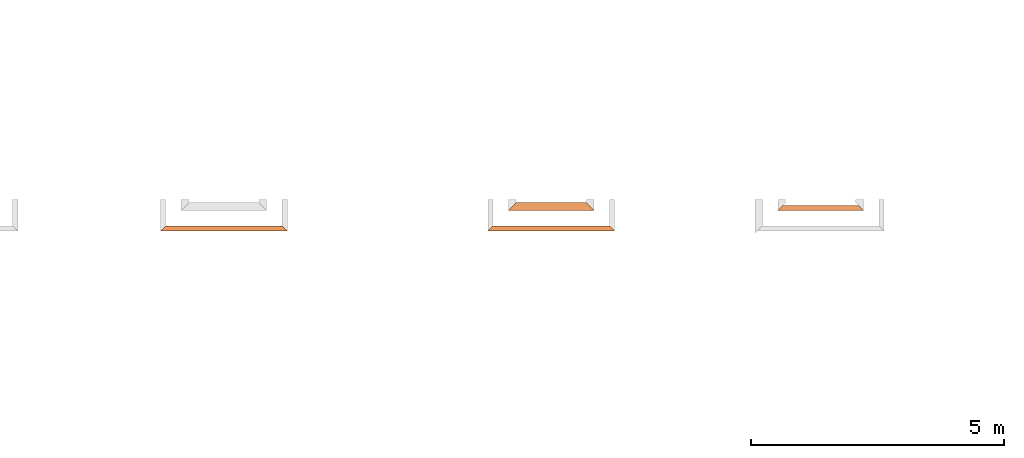
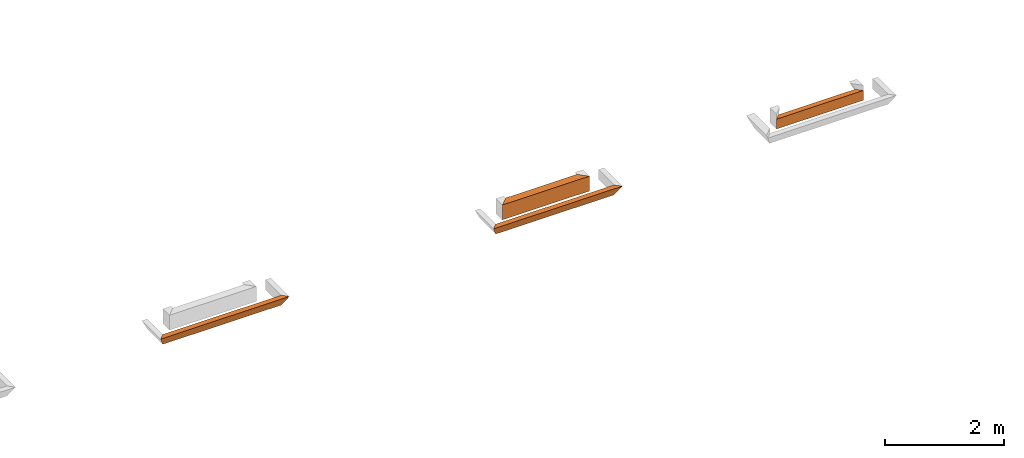
# One storey, part 3 of 8: 4 proxies.
"""IFC4 building model written with IfcOpenShell, lengths in feet."""

from ifc_helpers import new_model, entity, si_unit, converted_unit, derived_unit, direction, frame, origin, place, context, subcontext, project, spatial, type_object, element, save


model = new_model("IFC4")

# Units and contexts
model_context = context("Model", 3, precision=0.0001, world=origin(), true_north=direction((6.12303176911189e-17, 1.0)))
body_context = subcontext(model_context, "Body", "Model", "MODEL_VIEW")
ifc_project = project(units=[converted_unit("LENGTHUNIT", "FOOT", entity("IfcRatioMeasure", 0.3048), si_unit("LENGTHUNIT", "METRE"), dimensions=[1, 0, 0, 0, 0, 0, 0]), converted_unit("AREAUNIT", "SQUARE FOOT", entity("IfcRatioMeasure", 0.09290304), si_unit("AREAUNIT", "SQUARE_METRE"), dimensions=[2, 0, 0, 0, 0, 0, 0]), converted_unit("VOLUMEUNIT", "CUBIC FOOT", entity("IfcRatioMeasure", 0.028316846592), si_unit("VOLUMEUNIT", "CUBIC_METRE"), dimensions=[3, 0, 0, 0, 0, 0, 0]), converted_unit("PLANEANGLEUNIT", "DEGREE", entity("IfcRatioMeasure", 0.0174532925199433), si_unit("PLANEANGLEUNIT", "RADIAN"), dimensions=[0, 0, 0, 0, 0, 0, 0]), si_unit("MASSUNIT", "GRAM", prefix="KILO"), derived_unit("MASSDENSITYUNIT", [(si_unit("MASSUNIT", "GRAM", prefix="KILO"), 1), (si_unit("LENGTHUNIT", "METRE"), -3)]), derived_unit("MOMENTOFINERTIAUNIT", [(si_unit("LENGTHUNIT", "METRE"), 4)]), si_unit("TIMEUNIT", "SECOND"), si_unit("FREQUENCYUNIT", "HERTZ"), si_unit("THERMODYNAMICTEMPERATUREUNIT", "DEGREE_CELSIUS"), derived_unit("THERMALTRANSMITTANCEUNIT", [(si_unit("MASSUNIT", "GRAM", prefix="KILO"), 1), (si_unit("THERMODYNAMICTEMPERATUREUNIT", "KELVIN"), -1), (si_unit("TIMEUNIT", "SECOND"), -3)]), derived_unit("VOLUMETRICFLOWRATEUNIT", [(si_unit("LENGTHUNIT", "METRE"), 3), (si_unit("TIMEUNIT", "SECOND"), -1)]), si_unit("ELECTRICCURRENTUNIT", "AMPERE"), si_unit("ELECTRICVOLTAGEUNIT", "VOLT"), si_unit("POWERUNIT", "WATT"), si_unit("FORCEUNIT", "NEWTON"), si_unit("ILLUMINANCEUNIT", "LUX"), si_unit("LUMINOUSFLUXUNIT", "LUMEN"), si_unit("LUMINOUSINTENSITYUNIT", "CANDELA"), derived_unit("USERDEFINED", [(si_unit("MASSUNIT", "GRAM", prefix="KILO"), -1), (si_unit("LENGTHUNIT", "METRE"), -2), (si_unit("TIMEUNIT", "SECOND"), 3), (si_unit("LUMINOUSFLUXUNIT", "LUMEN"), 1)]), derived_unit("LINEARVELOCITYUNIT", [(si_unit("LENGTHUNIT", "METRE"), 1), (si_unit("TIMEUNIT", "SECOND"), -1)]), si_unit("PRESSUREUNIT", "PASCAL"), derived_unit("USERDEFINED", [(si_unit("LENGTHUNIT", "METRE"), -2), (si_unit("MASSUNIT", "GRAM", prefix="KILO"), 1), (si_unit("TIMEUNIT", "SECOND"), -2)]), derived_unit("LINEARFORCEUNIT", [(si_unit("MASSUNIT", "GRAM", prefix="KILO"), 1), (si_unit("LENGTHUNIT", "METRE"), 1), (si_unit("TIMEUNIT", "SECOND"), -2), (si_unit("LENGTHUNIT", "METRE"), -1)]), derived_unit("PLANARFORCEUNIT", [(si_unit("MASSUNIT", "GRAM", prefix="KILO"), 1), (si_unit("LENGTHUNIT", "METRE"), 1), (si_unit("TIMEUNIT", "SECOND"), -2), (si_unit("LENGTHUNIT", "METRE"), -2)])], contexts=[model_context])

# Site, building, storey
site_placement = place(None, origin())
site = spatial("IfcSite", under=ifc_project, at=site_placement, CompositionType="ELEMENT")
building_placement = place(site_placement, origin())
building = spatial("IfcBuilding", under=site, at=building_placement, CompositionType="ELEMENT")
storey_placement = place(building_placement, frame((0.0, 0.0, -12.6666666666667)))
storey = spatial("IfcBuildingStorey", under=building, at=storey_placement, Name="BASEMENT", CompositionType="ELEMENT", Elevation=-12.6666666666667)

# Proxies
building_element_proxy_type_1 = type_object("IfcBuildingElementProxyType", PredefinedType="NOTDEFINED")
proxy_1_placement = place(storey_placement, frame((-217.781129556124, 955.897091132649, 11.5833333333333)))
cartesian_point_1 = entity("IfcCartesianPoint", [7.87630257138792, 0.334635416666629, 0.0])
vertex_point_1 = entity("IfcVertexPoint", cartesian_point_1)
cartesian_point_2 = entity("IfcCartesianPoint", [7.87630257138792, 0.334635416666629, 0.669270833333334])
vertex_point_2 = entity("IfcVertexPoint", cartesian_point_2)
ifc_direction_1 = entity("IfcDirection", [0.0, 0.0, 1.0])
edge_curve_1 = entity("IfcEdgeCurve", vertex_point_1, vertex_point_2, entity("IfcTrimmedCurve", entity("IfcLine", cartesian_point_1, entity("IfcVector", ifc_direction_1, 1.0)), [cartesian_point_1], [cartesian_point_2], True, "CARTESIAN"), True)
cartesian_point_3 = entity("IfcCartesianPoint", [8.21093798805447, 0.0, 0.669270833333334])
vertex_point_3 = entity("IfcVertexPoint", cartesian_point_3)
edge_curve_2 = entity("IfcEdgeCurve", vertex_point_2, vertex_point_3, entity("IfcTrimmedCurve", entity("IfcLine", cartesian_point_2, entity("IfcVector", entity("IfcDirection", [0.707106781186548, -0.707106781186548, 0.0]), 1.0)), [cartesian_point_2], [cartesian_point_3], True, "CARTESIAN"), True)
edge_curve_3 = entity("IfcEdgeCurve", vertex_point_3, vertex_point_1, entity("IfcTrimmedCurve", entity("IfcLine", cartesian_point_3, entity("IfcVector", entity("IfcDirection", [-0.408248290463863, 0.408248290463829, -0.816496580927743]), 1.0)), [cartesian_point_3], [cartesian_point_1], True, "CARTESIAN"), True)
cartesian_point_4 = entity("IfcCartesianPoint", [0.334635416666714, 0.33463541666697, 0.0])
vertex_point_4 = entity("IfcVertexPoint", cartesian_point_4)
cartesian_point_5 = entity("IfcCartesianPoint", [0.0, 0.0, 0.669270833333334])
vertex_point_5 = entity("IfcVertexPoint", cartesian_point_5)
edge_curve_4 = entity("IfcEdgeCurve", vertex_point_4, vertex_point_5, entity("IfcTrimmedCurve", entity("IfcLine", cartesian_point_4, entity("IfcVector", entity("IfcDirection", [-0.408248290463863, -0.408248290463829, 0.816496580927743]), 1.0)), [cartesian_point_4], [cartesian_point_5], True, "CARTESIAN"), True)
cartesian_point_6 = entity("IfcCartesianPoint", [0.334635416666714, 0.33463541666697, 0.669270833333334])
vertex_point_6 = entity("IfcVertexPoint", cartesian_point_6)
edge_curve_5 = entity("IfcEdgeCurve", vertex_point_5, vertex_point_6, entity("IfcTrimmedCurve", entity("IfcLine", cartesian_point_5, entity("IfcVector", entity("IfcDirection", [0.707106781186517, 0.707106781186578, 0.0]), 1.0)), [cartesian_point_5], [cartesian_point_6], True, "CARTESIAN"), True)
edge_curve_6 = entity("IfcEdgeCurve", vertex_point_6, vertex_point_4, entity("IfcTrimmedCurve", entity("IfcLine", cartesian_point_6, entity("IfcVector", entity("IfcDirection", [0.0, 0.0, -1.0]), 1.0)), [cartesian_point_6], [cartesian_point_4], True, "CARTESIAN"), True)
ifc_direction_2 = entity("IfcDirection", [-1.0, 0.0, 0.0])
edge_curve_7 = entity("IfcEdgeCurve", vertex_point_1, vertex_point_4, entity("IfcTrimmedCurve", entity("IfcLine", cartesian_point_1, entity("IfcVector", ifc_direction_2, 1.0)), [cartesian_point_1], [cartesian_point_4], True, "CARTESIAN"), True)
cartesian_point_7 = entity("IfcCartesianPoint", [1.3346354166666, 0.33463541666697, 0.669270833333334])
vertex_point_7 = entity("IfcVertexPoint", cartesian_point_7)
ifc_direction_3 = entity("IfcDirection", [1.0, 0.0, 0.0])
edge_curve_8 = entity("IfcEdgeCurve", vertex_point_6, vertex_point_7, entity("IfcTrimmedCurve", entity("IfcLine", cartesian_point_6, entity("IfcVector", ifc_direction_3, 1.0)), [cartesian_point_6], [cartesian_point_7], True, "CARTESIAN"), True)
cartesian_point_8 = entity("IfcCartesianPoint", [4.45963573776979, 0.334635416666742, 0.669270833333334])
vertex_point_8 = entity("IfcVertexPoint", cartesian_point_8)
edge_curve_9 = entity("IfcEdgeCurve", vertex_point_7, vertex_point_8, entity("IfcTrimmedCurve", entity("IfcLine", cartesian_point_7, entity("IfcVector", ifc_direction_3, 1.0)), [cartesian_point_7], [cartesian_point_8], True, "CARTESIAN"), True)
cartesian_point_9 = entity("IfcCartesianPoint", [5.62630240443644, 0.334635416666742, 0.669270833333334])
vertex_point_9 = entity("IfcVertexPoint", cartesian_point_9)
edge_curve_10 = entity("IfcEdgeCurve", vertex_point_8, vertex_point_9, entity("IfcTrimmedCurve", entity("IfcLine", cartesian_point_8, entity("IfcVector", ifc_direction_3, 1.0)), [cartesian_point_8], [cartesian_point_9], True, "CARTESIAN"), True)
cartesian_point_10 = entity("IfcCartesianPoint", [6.87630257138792, 0.334635416666629, 0.669270833333334])
vertex_point_10 = entity("IfcVertexPoint", cartesian_point_10)
edge_curve_11 = entity("IfcEdgeCurve", vertex_point_9, vertex_point_10, entity("IfcTrimmedCurve", entity("IfcLine", cartesian_point_9, entity("IfcVector", ifc_direction_3, 1.0)), [cartesian_point_9], [cartesian_point_10], True, "CARTESIAN"), True)
edge_curve_12 = entity("IfcEdgeCurve", vertex_point_10, vertex_point_2, entity("IfcTrimmedCurve", entity("IfcLine", cartesian_point_10, entity("IfcVector", ifc_direction_3, 1.0)), [cartesian_point_10], [cartesian_point_2], True, "CARTESIAN"), True)
edge_curve_13 = entity("IfcEdgeCurve", vertex_point_3, vertex_point_5, entity("IfcTrimmedCurve", entity("IfcLine", cartesian_point_3, entity("IfcVector", ifc_direction_2, 1.0)), [cartesian_point_3], [cartesian_point_5], True, "CARTESIAN"), True)
element("IfcBuildingElementProxy", 1, at=proxy_1_placement, inside=storey, type_object=building_element_proxy_type_1, PredefinedType="NOTDEFINED", context=body_context, shape_type="AdvancedBrep", body=[
    entity("IfcAdvancedBrep", entity("IfcClosedShell", [entity("IfcAdvancedFace", [entity("IfcFaceOuterBound", entity("IfcEdgeLoop", [entity("IfcOrientedEdge", None, None, edge_curve_1, True), entity("IfcOrientedEdge", None, None, edge_curve_2, True), entity("IfcOrientedEdge", None, None, edge_curve_3, True)]), True)], entity("IfcPlane", entity("IfcAxis2Placement3D", entity("IfcCartesianPoint", [7.87630257138792, 0.334635416666629, 2.0]), entity("IfcDirection", [0.707106781186562, 0.707106781186533, 0.0]), entity("IfcDirection", [-0.707106781186533, 0.707106781186562, 0.0]))), True), entity("IfcAdvancedFace", [entity("IfcFaceOuterBound", entity("IfcEdgeLoop", [entity("IfcOrientedEdge", None, None, edge_curve_4, True), entity("IfcOrientedEdge", None, None, edge_curve_5, True), entity("IfcOrientedEdge", None, None, edge_curve_6, True)]), True)], entity("IfcPlane", entity("IfcAxis2Placement3D", entity("IfcCartesianPoint", [0.3346354166666, 0.334635416666856, 2.0]), entity("IfcDirection", [-0.707106781186548, 0.707106781186548, 0.0]), entity("IfcDirection", [0.707106781186548, 0.707106781186548, 0.0]))), True), entity("IfcAdvancedFace", [entity("IfcFaceOuterBound", entity("IfcEdgeLoop", [entity("IfcOrientedEdge", None, None, edge_curve_7, True), entity("IfcOrientedEdge", None, None, edge_curve_6, False), entity("IfcOrientedEdge", None, None, edge_curve_8, True), entity("IfcOrientedEdge", None, None, edge_curve_9, True), entity("IfcOrientedEdge", None, None, edge_curve_10, True), entity("IfcOrientedEdge", None, None, edge_curve_11, True), entity("IfcOrientedEdge", None, None, edge_curve_12, True), entity("IfcOrientedEdge", None, None, edge_curve_1, False)]), True)], entity("IfcPlane", entity("IfcAxis2Placement3D", cartesian_point_1, entity("IfcDirection", [0.0, 1.0, 0.0]), ifc_direction_2)), True), entity("IfcAdvancedFace", [entity("IfcFaceOuterBound", entity("IfcEdgeLoop", [entity("IfcOrientedEdge", None, None, edge_curve_7, False), entity("IfcOrientedEdge", None, None, edge_curve_3, False), entity("IfcOrientedEdge", None, None, edge_curve_13, True), entity("IfcOrientedEdge", None, None, edge_curve_4, False)]), True)], entity("IfcPlane", entity("IfcAxis2Placement3D", entity("IfcCartesianPoint", [8.37630257138792, -0.165364583333371, 1.0]), entity("IfcDirection", [0.0, -0.894427190999915, -0.447213595499961]), ifc_direction_2)), True), entity("IfcAdvancedFace", [entity("IfcFaceOuterBound", entity("IfcEdgeLoop", [entity("IfcOrientedEdge", None, None, edge_curve_2, False), entity("IfcOrientedEdge", None, None, edge_curve_12, False), entity("IfcOrientedEdge", None, None, edge_curve_11, False), entity("IfcOrientedEdge", None, None, edge_curve_10, False), entity("IfcOrientedEdge", None, None, edge_curve_9, False), entity("IfcOrientedEdge", None, None, edge_curve_8, False), entity("IfcOrientedEdge", None, None, edge_curve_5, False), entity("IfcOrientedEdge", None, None, edge_curve_13, False)]), True)], entity("IfcPlane", entity("IfcAxis2Placement3D", entity("IfcCartesianPoint", [76.0429767451503, 2.96484375000114, 0.669270833333334]), ifc_direction_1, ifc_direction_3)), True)])),
])
building_element_proxy_type_2 = type_object("IfcBuildingElementProxyType", PredefinedType="NOTDEFINED")
proxy_2_placement = place(storey_placement, frame((-195.238160652997, 957.231726549315, 11.5833333333333)))
cartesian_point_11 = entity("IfcCartesianPoint", [5.54166715473104, 0.0, 0.0])
vertex_point_11 = entity("IfcVertexPoint", cartesian_point_11)
cartesian_point_12 = entity("IfcCartesianPoint", [5.04166715473104, 0.5, 1.0])
vertex_point_12 = entity("IfcVertexPoint", cartesian_point_12)
edge_curve_14 = entity("IfcEdgeCurve", vertex_point_11, vertex_point_12, entity("IfcTrimmedCurve", entity("IfcLine", cartesian_point_11, entity("IfcVector", entity("IfcDirection", [-0.408248290463864, 0.408248290463864, 0.816496580927725]), 1.0)), [cartesian_point_11], [cartesian_point_12], True, "CARTESIAN"), True)
cartesian_point_13 = entity("IfcCartesianPoint", [5.54166715473104, 0.0, 1.0])
vertex_point_13 = entity("IfcVertexPoint", cartesian_point_13)
edge_curve_15 = entity("IfcEdgeCurve", vertex_point_12, vertex_point_13, entity("IfcTrimmedCurve", entity("IfcLine", cartesian_point_12, entity("IfcVector", entity("IfcDirection", [0.707106781186547, -0.707106781186547, 0.0]), 1.0)), [cartesian_point_12], [cartesian_point_13], True, "CARTESIAN"), True)
cartesian_point_14 = entity("IfcCartesianPoint", [5.54166715473104, 0.0, 0.669270833333334])
vertex_point_14 = entity("IfcVertexPoint", cartesian_point_14)
ifc_direction_4 = entity("IfcDirection", [0.0, 0.0, -1.0])
edge_curve_16 = entity("IfcEdgeCurve", vertex_point_13, vertex_point_14, entity("IfcTrimmedCurve", entity("IfcLine", cartesian_point_13, entity("IfcVector", ifc_direction_4, 1.0)), [cartesian_point_13], [cartesian_point_14], True, "CARTESIAN"), True)
edge_curve_17 = entity("IfcEdgeCurve", vertex_point_14, vertex_point_11, entity("IfcTrimmedCurve", entity("IfcLine", cartesian_point_14, entity("IfcVector", ifc_direction_4, 1.0)), [cartesian_point_14], [cartesian_point_11], True, "CARTESIAN"), True)
cartesian_point_15 = entity("IfcCartesianPoint", [0.499999999999972, 0.500000000000227, 1.0])
vertex_point_15 = entity("IfcVertexPoint", cartesian_point_15)
cartesian_point_16 = entity("IfcCartesianPoint", [0.0, 0.0, 0.0])
vertex_point_16 = entity("IfcVertexPoint", cartesian_point_16)
edge_curve_18 = entity("IfcEdgeCurve", vertex_point_15, vertex_point_16, entity("IfcTrimmedCurve", entity("IfcLine", cartesian_point_15, entity("IfcVector", entity("IfcDirection", [-0.408248290463845, -0.408248290463868, -0.816496580927732]), 1.0)), [cartesian_point_15], [cartesian_point_16], True, "CARTESIAN"), True)
cartesian_point_17 = entity("IfcCartesianPoint", [0.0, 0.0, 0.669270833333334])
vertex_point_17 = entity("IfcVertexPoint", cartesian_point_17)
ifc_direction_5 = entity("IfcDirection", [0.0, 0.0, 1.0])
edge_curve_19 = entity("IfcEdgeCurve", vertex_point_16, vertex_point_17, entity("IfcTrimmedCurve", entity("IfcLine", cartesian_point_16, entity("IfcVector", ifc_direction_5, 1.0)), [cartesian_point_16], [cartesian_point_17], True, "CARTESIAN"), True)
cartesian_point_18 = entity("IfcCartesianPoint", [0.0, 0.0, 1.0])
vertex_point_18 = entity("IfcVertexPoint", cartesian_point_18)
edge_curve_20 = entity("IfcEdgeCurve", vertex_point_17, vertex_point_18, entity("IfcTrimmedCurve", entity("IfcLine", cartesian_point_17, entity("IfcVector", ifc_direction_5, 1.0)), [cartesian_point_17], [cartesian_point_18], True, "CARTESIAN"), True)
edge_curve_21 = entity("IfcEdgeCurve", vertex_point_18, vertex_point_15, entity("IfcTrimmedCurve", entity("IfcLine", cartesian_point_18, entity("IfcVector", entity("IfcDirection", [0.707106781186527, 0.707106781186568, 0.0]), 1.0)), [cartesian_point_18], [cartesian_point_15], True, "CARTESIAN"), True)
ifc_direction_6 = entity("IfcDirection", [-1.0, 0.0, 0.0])
edge_curve_22 = entity("IfcEdgeCurve", vertex_point_11, vertex_point_16, entity("IfcTrimmedCurve", entity("IfcLine", cartesian_point_11, entity("IfcVector", ifc_direction_6, 1.0)), [cartesian_point_11], [cartesian_point_16], True, "CARTESIAN"), True)
ifc_direction_7 = entity("IfcDirection", [1.0, 0.0, 0.0])
edge_curve_23 = entity("IfcEdgeCurve", vertex_point_15, vertex_point_12, entity("IfcTrimmedCurve", entity("IfcLine", cartesian_point_12, entity("IfcVector", ifc_direction_7, 1.0)), [cartesian_point_15], [cartesian_point_12], True, "CARTESIAN"), True)
edge_curve_24 = entity("IfcEdgeCurve", vertex_point_18, vertex_point_13, entity("IfcTrimmedCurve", entity("IfcLine", cartesian_point_13, entity("IfcVector", ifc_direction_7, 1.0)), [cartesian_point_18], [cartesian_point_13], True, "CARTESIAN"), True)
element("IfcBuildingElementProxy", 2, at=proxy_2_placement, inside=storey, type_object=building_element_proxy_type_2, PredefinedType="NOTDEFINED", context=body_context, shape_type="AdvancedBrep", body=[
    entity("IfcAdvancedBrep", entity("IfcClosedShell", [entity("IfcAdvancedFace", [entity("IfcFaceOuterBound", entity("IfcEdgeLoop", [entity("IfcOrientedEdge", None, None, edge_curve_14, True), entity("IfcOrientedEdge", None, None, edge_curve_15, True), entity("IfcOrientedEdge", None, None, edge_curve_16, True), entity("IfcOrientedEdge", None, None, edge_curve_17, True)]), True)], entity("IfcPlane", entity("IfcAxis2Placement3D", entity("IfcCartesianPoint", [5.54166715473104, 0.0, 2.0]), entity("IfcDirection", [0.707106781186562, 0.707106781186533, 0.0]), entity("IfcDirection", [-0.707106781186533, 0.707106781186562, 0.0]))), True), entity("IfcAdvancedFace", [entity("IfcFaceOuterBound", entity("IfcEdgeLoop", [entity("IfcOrientedEdge", None, None, edge_curve_18, True), entity("IfcOrientedEdge", None, None, edge_curve_19, True), entity("IfcOrientedEdge", None, None, edge_curve_20, True), entity("IfcOrientedEdge", None, None, edge_curve_21, True)]), True)], entity("IfcPlane", entity("IfcAxis2Placement3D", entity("IfcCartesianPoint", [0.0, 0.0, 2.0]), entity("IfcDirection", [-0.707106781186548, 0.707106781186548, 0.0]), entity("IfcDirection", [0.707106781186548, 0.707106781186548, 0.0]))), True), entity("IfcAdvancedFace", [entity("IfcFaceOuterBound", entity("IfcEdgeLoop", [entity("IfcOrientedEdge", None, None, edge_curve_14, False), entity("IfcOrientedEdge", None, None, edge_curve_22, True), entity("IfcOrientedEdge", None, None, edge_curve_18, False), entity("IfcOrientedEdge", None, None, edge_curve_23, True)]), True)], entity("IfcPlane", entity("IfcAxis2Placement3D", cartesian_point_11, entity("IfcDirection", [0.0, 0.894427190999915, -0.447213595499961]), ifc_direction_6)), True), entity("IfcAdvancedFace", [entity("IfcFaceOuterBound", entity("IfcEdgeLoop", [entity("IfcOrientedEdge", None, None, edge_curve_15, False), entity("IfcOrientedEdge", None, None, edge_curve_23, False), entity("IfcOrientedEdge", None, None, edge_curve_21, False), entity("IfcOrientedEdge", None, None, edge_curve_24, True)]), True)], entity("IfcPlane", entity("IfcAxis2Placement3D", cartesian_point_12, ifc_direction_5, ifc_direction_6)), True), entity("IfcAdvancedFace", [entity("IfcFaceOuterBound", entity("IfcEdgeLoop", [entity("IfcOrientedEdge", None, None, edge_curve_24, False), entity("IfcOrientedEdge", None, None, edge_curve_20, False), entity("IfcOrientedEdge", None, None, edge_curve_19, False), entity("IfcOrientedEdge", None, None, edge_curve_22, False), entity("IfcOrientedEdge", None, None, edge_curve_17, False), entity("IfcOrientedEdge", None, None, edge_curve_16, False)]), True)], entity("IfcPlane", entity("IfcAxis2Placement3D", cartesian_point_13, entity("IfcDirection", [0.0, -1.0, 0.0]), ifc_direction_6)), True)])),
])
building_element_proxy_type_3 = type_object("IfcBuildingElementProxyType", PredefinedType="NOTDEFINED")
proxy_3_placement = place(storey_placement, frame((-196.572796069664, 955.897091132648, 11.5833333333333)))
cartesian_point_19 = entity("IfcCartesianPoint", [7.87630257139756, 0.334635416666629, 0.0])
vertex_point_19 = entity("IfcVertexPoint", cartesian_point_19)
cartesian_point_20 = entity("IfcCartesianPoint", [7.87630257139756, 0.334635416666629, 0.669270833333334])
vertex_point_20 = entity("IfcVertexPoint", cartesian_point_20)
ifc_direction_8 = entity("IfcDirection", [0.0, 0.0, 1.0])
edge_curve_25 = entity("IfcEdgeCurve", vertex_point_19, vertex_point_20, entity("IfcTrimmedCurve", entity("IfcLine", cartesian_point_19, entity("IfcVector", ifc_direction_8, 1.0)), [cartesian_point_19], [cartesian_point_20], True, "CARTESIAN"), True)
cartesian_point_21 = entity("IfcCartesianPoint", [8.21093798806413, 0.0, 0.669270833333334])
vertex_point_21 = entity("IfcVertexPoint", cartesian_point_21)
edge_curve_26 = entity("IfcEdgeCurve", vertex_point_20, vertex_point_21, entity("IfcTrimmedCurve", entity("IfcLine", cartesian_point_20, entity("IfcVector", entity("IfcDirection", [0.707106781186488, -0.707106781186608, 0.0]), 1.0)), [cartesian_point_20], [cartesian_point_21], True, "CARTESIAN"), True)
edge_curve_27 = entity("IfcEdgeCurve", vertex_point_21, vertex_point_19, entity("IfcTrimmedCurve", entity("IfcLine", cartesian_point_21, entity("IfcVector", entity("IfcDirection", [-0.408248290463863, 0.408248290463829, -0.816496580927743]), 1.0)), [cartesian_point_21], [cartesian_point_19], True, "CARTESIAN"), True)
cartesian_point_22 = entity("IfcCartesianPoint", [0.334635416666686, 0.33463541666697, 0.0])
vertex_point_22 = entity("IfcVertexPoint", cartesian_point_22)
cartesian_point_23 = entity("IfcCartesianPoint", [0.0, 0.0, 0.669270833333334])
vertex_point_23 = entity("IfcVertexPoint", cartesian_point_23)
edge_curve_28 = entity("IfcEdgeCurve", vertex_point_22, vertex_point_23, entity("IfcTrimmedCurve", entity("IfcLine", cartesian_point_22, entity("IfcVector", entity("IfcDirection", [-0.408248290463863, -0.408248290463829, 0.816496580927743]), 1.0)), [cartesian_point_22], [cartesian_point_23], True, "CARTESIAN"), True)
cartesian_point_24 = entity("IfcCartesianPoint", [0.334635416666686, 0.33463541666697, 0.669270833333334])
vertex_point_24 = entity("IfcVertexPoint", cartesian_point_24)
edge_curve_29 = entity("IfcEdgeCurve", vertex_point_23, vertex_point_24, entity("IfcTrimmedCurve", entity("IfcLine", cartesian_point_23, entity("IfcVector", entity("IfcDirection", [0.707106781186488, 0.707106781186608, 0.0]), 1.0)), [cartesian_point_23], [cartesian_point_24], True, "CARTESIAN"), True)
edge_curve_30 = entity("IfcEdgeCurve", vertex_point_24, vertex_point_22, entity("IfcTrimmedCurve", entity("IfcLine", cartesian_point_24, entity("IfcVector", entity("IfcDirection", [0.0, 0.0, -1.0]), 1.0)), [cartesian_point_24], [cartesian_point_22], True, "CARTESIAN"), True)
ifc_direction_9 = entity("IfcDirection", [-1.0, 0.0, 0.0])
edge_curve_31 = entity("IfcEdgeCurve", vertex_point_19, vertex_point_22, entity("IfcTrimmedCurve", entity("IfcLine", cartesian_point_19, entity("IfcVector", ifc_direction_9, 1.0)), [cartesian_point_19], [cartesian_point_22], True, "CARTESIAN"), True)
cartesian_point_25 = entity("IfcCartesianPoint", [1.33463541666657, 0.33463541666697, 0.669270833333334])
vertex_point_25 = entity("IfcVertexPoint", cartesian_point_25)
ifc_direction_10 = entity("IfcDirection", [1.0, 0.0, 0.0])
edge_curve_32 = entity("IfcEdgeCurve", vertex_point_24, vertex_point_25, entity("IfcTrimmedCurve", entity("IfcLine", cartesian_point_24, entity("IfcVector", ifc_direction_10, 1.0)), [cartesian_point_24], [cartesian_point_25], True, "CARTESIAN"), True)
cartesian_point_26 = entity("IfcCartesianPoint", [2.5846355840587, 0.334635416666856, 0.669270833333334])
vertex_point_26 = entity("IfcVertexPoint", cartesian_point_26)
edge_curve_33 = entity("IfcEdgeCurve", vertex_point_25, vertex_point_26, entity("IfcTrimmedCurve", entity("IfcLine", cartesian_point_25, entity("IfcVector", ifc_direction_10, 1.0)), [cartesian_point_25], [cartesian_point_26], True, "CARTESIAN"), True)
cartesian_point_27 = entity("IfcCartesianPoint", [3.75130225072536, 0.334635416666856, 0.669270833333334])
vertex_point_27 = entity("IfcVertexPoint", cartesian_point_27)
edge_curve_34 = entity("IfcEdgeCurve", vertex_point_26, vertex_point_27, entity("IfcTrimmedCurve", entity("IfcLine", cartesian_point_26, entity("IfcVector", ifc_direction_10, 1.0)), [cartesian_point_26], [cartesian_point_27], True, "CARTESIAN"), True)
cartesian_point_28 = entity("IfcCartesianPoint", [6.87630257139756, 0.334635416666629, 0.669270833333334])
vertex_point_28 = entity("IfcVertexPoint", cartesian_point_28)
edge_curve_35 = entity("IfcEdgeCurve", vertex_point_27, vertex_point_28, entity("IfcTrimmedCurve", entity("IfcLine", cartesian_point_27, entity("IfcVector", ifc_direction_10, 1.0)), [cartesian_point_27], [cartesian_point_28], True, "CARTESIAN"), True)
edge_curve_36 = entity("IfcEdgeCurve", vertex_point_28, vertex_point_20, entity("IfcTrimmedCurve", entity("IfcLine", cartesian_point_28, entity("IfcVector", ifc_direction_10, 1.0)), [cartesian_point_28], [cartesian_point_20], True, "CARTESIAN"), True)
edge_curve_37 = entity("IfcEdgeCurve", vertex_point_21, vertex_point_23, entity("IfcTrimmedCurve", entity("IfcLine", cartesian_point_21, entity("IfcVector", ifc_direction_9, 1.0)), [cartesian_point_21], [cartesian_point_23], True, "CARTESIAN"), True)
element("IfcBuildingElementProxy", 3, at=proxy_3_placement, inside=storey, type_object=building_element_proxy_type_3, PredefinedType="NOTDEFINED", context=body_context, shape_type="AdvancedBrep", body=[
    entity("IfcAdvancedBrep", entity("IfcClosedShell", [entity("IfcAdvancedFace", [entity("IfcFaceOuterBound", entity("IfcEdgeLoop", [entity("IfcOrientedEdge", None, None, edge_curve_25, True), entity("IfcOrientedEdge", None, None, edge_curve_26, True), entity("IfcOrientedEdge", None, None, edge_curve_27, True)]), True)], entity("IfcPlane", entity("IfcAxis2Placement3D", entity("IfcCartesianPoint", [7.87630257139756, 0.334635416666629, 2.0]), entity("IfcDirection", [0.707106781186562, 0.707106781186533, 0.0]), entity("IfcDirection", [-0.707106781186533, 0.707106781186562, 0.0]))), True), entity("IfcAdvancedFace", [entity("IfcFaceOuterBound", entity("IfcEdgeLoop", [entity("IfcOrientedEdge", None, None, edge_curve_28, True), entity("IfcOrientedEdge", None, None, edge_curve_29, True), entity("IfcOrientedEdge", None, None, edge_curve_30, True)]), True)], entity("IfcPlane", entity("IfcAxis2Placement3D", entity("IfcCartesianPoint", [0.334635416666572, 0.334635416666856, 2.0]), entity("IfcDirection", [-0.707106781186548, 0.707106781186548, 0.0]), entity("IfcDirection", [0.707106781186548, 0.707106781186548, 0.0]))), True), entity("IfcAdvancedFace", [entity("IfcFaceOuterBound", entity("IfcEdgeLoop", [entity("IfcOrientedEdge", None, None, edge_curve_31, True), entity("IfcOrientedEdge", None, None, edge_curve_30, False), entity("IfcOrientedEdge", None, None, edge_curve_32, True), entity("IfcOrientedEdge", None, None, edge_curve_33, True), entity("IfcOrientedEdge", None, None, edge_curve_34, True), entity("IfcOrientedEdge", None, None, edge_curve_35, True), entity("IfcOrientedEdge", None, None, edge_curve_36, True), entity("IfcOrientedEdge", None, None, edge_curve_25, False)]), True)], entity("IfcPlane", entity("IfcAxis2Placement3D", cartesian_point_19, entity("IfcDirection", [0.0, 1.0, 0.0]), ifc_direction_9)), True), entity("IfcAdvancedFace", [entity("IfcFaceOuterBound", entity("IfcEdgeLoop", [entity("IfcOrientedEdge", None, None, edge_curve_31, False), entity("IfcOrientedEdge", None, None, edge_curve_27, False), entity("IfcOrientedEdge", None, None, edge_curve_37, True), entity("IfcOrientedEdge", None, None, edge_curve_28, False)]), True)], entity("IfcPlane", entity("IfcAxis2Placement3D", entity("IfcCartesianPoint", [8.37630257139756, -0.165364583333371, 1.0]), entity("IfcDirection", [0.0, -0.894427190999915, -0.447213595499961]), ifc_direction_9)), True), entity("IfcAdvancedFace", [entity("IfcFaceOuterBound", entity("IfcEdgeLoop", [entity("IfcOrientedEdge", None, None, edge_curve_26, False), entity("IfcOrientedEdge", None, None, edge_curve_36, False), entity("IfcOrientedEdge", None, None, edge_curve_35, False), entity("IfcOrientedEdge", None, None, edge_curve_34, False), entity("IfcOrientedEdge", None, None, edge_curve_33, False), entity("IfcOrientedEdge", None, None, edge_curve_32, False), entity("IfcOrientedEdge", None, None, edge_curve_29, False), entity("IfcOrientedEdge", None, None, edge_curve_37, False)]), True)], entity("IfcPlane", entity("IfcAxis2Placement3D", entity("IfcCartesianPoint", [54.8346432586897, 2.96484375000216, 0.669270833333334]), ifc_direction_8, ifc_direction_10)), True)])),
])
building_element_proxy_type_4 = type_object("IfcBuildingElementProxyType", PredefinedType="NOTDEFINED")
proxy_4_placement = place(storey_placement, frame((-177.779827442686, 957.231726549315, 11.5833333333333)))
cartesian_point_29 = entity("IfcCartesianPoint", [5.5416671547116, 0.0, 0.0])
vertex_point_29 = entity("IfcVertexPoint", cartesian_point_29)
cartesian_point_30 = entity("IfcCartesianPoint", [5.21181498777273, 0.329852166938736, 0.659704333877778])
vertex_point_30 = entity("IfcVertexPoint", cartesian_point_30)
edge_curve_38 = entity("IfcEdgeCurve", vertex_point_29, vertex_point_30, entity("IfcTrimmedCurve", entity("IfcLine", cartesian_point_29, entity("IfcVector", entity("IfcDirection", [-0.408248290463861, 0.408248290463826, 0.816496580927745]), 1.0)), [cartesian_point_29], [cartesian_point_30], True, "CARTESIAN"), True)
cartesian_point_31 = entity("IfcCartesianPoint", [5.5416671547116, 0.0, 0.666576254022337])
vertex_point_31 = entity("IfcVertexPoint", cartesian_point_31)
edge_curve_39 = entity("IfcEdgeCurve", vertex_point_30, vertex_point_31, entity("IfcTrimmedCurve", entity("IfcLine", cartesian_point_30, entity("IfcVector", entity("IfcDirection", [0.707030067676022, -0.707030067676022, 0.0147297930765863]), 1.0)), [cartesian_point_30], [cartesian_point_31], True, "CARTESIAN"), True)
edge_curve_40 = entity("IfcEdgeCurve", vertex_point_31, vertex_point_29, entity("IfcTrimmedCurve", entity("IfcLine", cartesian_point_31, entity("IfcVector", entity("IfcDirection", [0.0, 0.0, -1.0]), 1.0)), [cartesian_point_31], [cartesian_point_29], True, "CARTESIAN"), True)
cartesian_point_32 = entity("IfcCartesianPoint", [0.0, 0.0, 0.0])
vertex_point_32 = entity("IfcVertexPoint", cartesian_point_32)
cartesian_point_33 = entity("IfcCartesianPoint", [0.0, 0.0, 0.666576254022335])
vertex_point_33 = entity("IfcVertexPoint", cartesian_point_33)
edge_curve_41 = entity("IfcEdgeCurve", vertex_point_32, vertex_point_33, entity("IfcTrimmedCurve", entity("IfcLine", cartesian_point_32, entity("IfcVector", entity("IfcDirection", [0.0, 0.0, 1.0]), 1.0)), [cartesian_point_32], [cartesian_point_33], True, "CARTESIAN"), True)
cartesian_point_34 = entity("IfcCartesianPoint", [0.329852166938849, 0.329852166938963, 0.659704333877773])
vertex_point_34 = entity("IfcVertexPoint", cartesian_point_34)
edge_curve_42 = entity("IfcEdgeCurve", vertex_point_33, vertex_point_34, entity("IfcTrimmedCurve", entity("IfcLine", cartesian_point_33, entity("IfcVector", entity("IfcDirection", [0.707030067676022, 0.707030067676022, -0.0147297930765841]), 1.0)), [cartesian_point_33], [cartesian_point_34], True, "CARTESIAN"), True)
edge_curve_43 = entity("IfcEdgeCurve", vertex_point_34, vertex_point_32, entity("IfcTrimmedCurve", entity("IfcLine", cartesian_point_34, entity("IfcVector", entity("IfcDirection", [-0.408248290463863, -0.408248290463828, -0.816496580927743]), 1.0)), [cartesian_point_34], [cartesian_point_32], True, "CARTESIAN"), True)
ifc_direction_11 = entity("IfcDirection", [-1.0, 0.0, 0.0])
edge_curve_44 = entity("IfcEdgeCurve", vertex_point_29, vertex_point_32, entity("IfcTrimmedCurve", entity("IfcLine", cartesian_point_29, entity("IfcVector", ifc_direction_11, 1.0)), [cartesian_point_29], [cartesian_point_32], True, "CARTESIAN"), True)
edge_curve_45 = entity("IfcEdgeCurve", vertex_point_34, vertex_point_30, entity("IfcTrimmedCurve", entity("IfcLine", cartesian_point_34, entity("IfcVector", entity("IfcDirection", [1.0, 0.0, 0.0]), 1.0)), [cartesian_point_34], [cartesian_point_30], True, "CARTESIAN"), True)
edge_curve_46 = entity("IfcEdgeCurve", vertex_point_31, vertex_point_33, entity("IfcTrimmedCurve", entity("IfcLine", cartesian_point_31, entity("IfcVector", ifc_direction_11, 1.0)), [cartesian_point_31], [cartesian_point_33], True, "CARTESIAN"), True)
element("IfcBuildingElementProxy", 4, at=proxy_4_placement, inside=storey, type_object=building_element_proxy_type_4, PredefinedType="NOTDEFINED", context=body_context, shape_type="AdvancedBrep", body=[
    entity("IfcAdvancedBrep", entity("IfcClosedShell", [entity("IfcAdvancedFace", [entity("IfcFaceOuterBound", entity("IfcEdgeLoop", [entity("IfcOrientedEdge", None, None, edge_curve_38, True), entity("IfcOrientedEdge", None, None, edge_curve_39, True), entity("IfcOrientedEdge", None, None, edge_curve_40, True)]), True)], entity("IfcPlane", entity("IfcAxis2Placement3D", entity("IfcCartesianPoint", [5.5416671547116, 0.0, 2.0]), entity("IfcDirection", [0.707106781186562, 0.707106781186533, 0.0]), entity("IfcDirection", [-0.707106781186533, 0.707106781186562, 0.0]))), True), entity("IfcAdvancedFace", [entity("IfcFaceOuterBound", entity("IfcEdgeLoop", [entity("IfcOrientedEdge", None, None, edge_curve_41, True), entity("IfcOrientedEdge", None, None, edge_curve_42, True), entity("IfcOrientedEdge", None, None, edge_curve_43, True)]), True)], entity("IfcPlane", entity("IfcAxis2Placement3D", entity("IfcCartesianPoint", [0.0, 0.0, 2.0]), entity("IfcDirection", [-0.707106781186548, 0.707106781186548, 0.0]), entity("IfcDirection", [0.707106781186548, 0.707106781186548, 0.0]))), True), entity("IfcAdvancedFace", [entity("IfcFaceOuterBound", entity("IfcEdgeLoop", [entity("IfcOrientedEdge", None, None, edge_curve_44, True), entity("IfcOrientedEdge", None, None, edge_curve_43, False), entity("IfcOrientedEdge", None, None, edge_curve_45, True), entity("IfcOrientedEdge", None, None, edge_curve_38, False)]), True)], entity("IfcPlane", entity("IfcAxis2Placement3D", cartesian_point_29, entity("IfcDirection", [0.0, 0.894427190999915, -0.447213595499961]), ifc_direction_11)), True), entity("IfcAdvancedFace", [entity("IfcFaceOuterBound", entity("IfcEdgeLoop", [entity("IfcOrientedEdge", None, None, edge_curve_44, False), entity("IfcOrientedEdge", None, None, edge_curve_40, False), entity("IfcOrientedEdge", None, None, edge_curve_46, True), entity("IfcOrientedEdge", None, None, edge_curve_41, False)]), True)], entity("IfcPlane", entity("IfcAxis2Placement3D", entity("IfcCartesianPoint", [5.5416671547116, 0.0, 1.0]), entity("IfcDirection", [0.0, -1.0, 0.0]), ifc_direction_11)), True), entity("IfcAdvancedFace", [entity("IfcFaceOuterBound", entity("IfcEdgeLoop", [entity("IfcOrientedEdge", None, None, edge_curve_39, False), entity("IfcOrientedEdge", None, None, edge_curve_45, False), entity("IfcOrientedEdge", None, None, edge_curve_42, False), entity("IfcOrientedEdge", None, None, edge_curve_46, False)]), True)], entity("IfcPlane", entity("IfcAxis2Placement3D", entity("IfcCartesianPoint", [-75.4583330146403, 0.0, 0.666576254022299]), entity("IfcDirection", [0.0, 0.0208288136818357, 0.999783056728112]), entity("IfcDirection", [0.0, -0.999783056728112, 0.0208288136818357]))), True)])),
])

save(model, "model.ifc")
